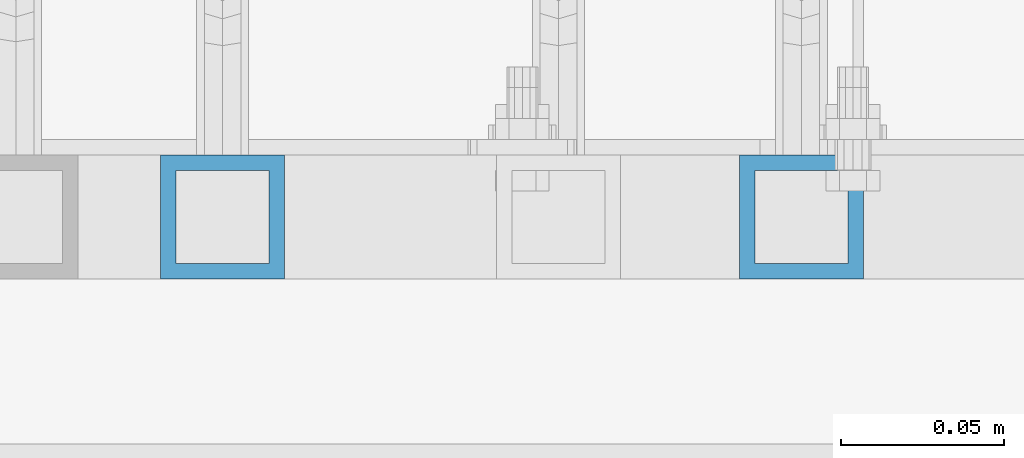
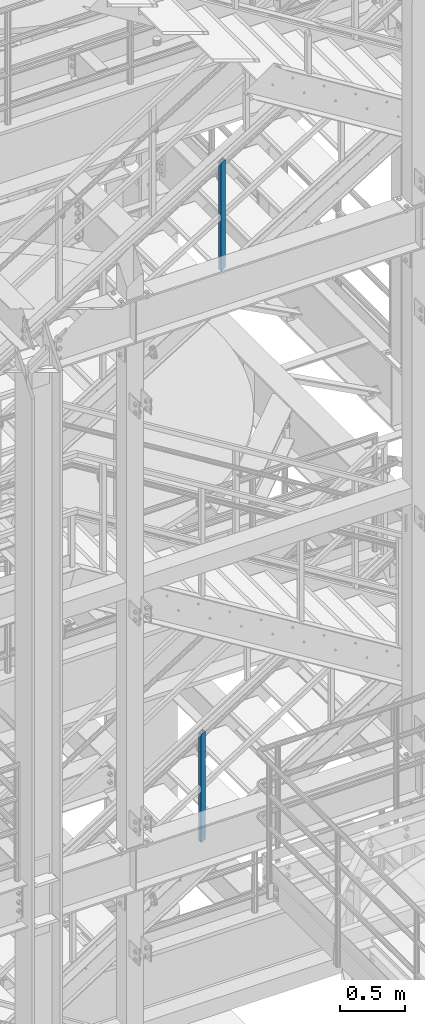
# One storey, part 624 of 1876: 2 columns, 2 elements without a shape of their own.
"""IFC2X3 building model written with IfcOpenShell, lengths in millimetres."""

from ifc_helpers import new_model, si_unit, frame, origin_with_axes, place, context, subcontext, project, spatial, faceted_brep, material, type_object, element, aggregate, save


model = new_model("IFC2X3")

# Units and contexts
model_context = context("Model", 3, precision=1e-05, world=origin_with_axes())
body_context = subcontext(model_context, "Body", "Model", "MODEL_VIEW")
ifc_project = project(units=[si_unit("LENGTHUNIT", "METRE", prefix="MILLI"), si_unit("AREAUNIT", "SQUARE_METRE"), si_unit("VOLUMEUNIT", "CUBIC_METRE"), si_unit("MASSUNIT", "GRAM", prefix="KILO"), si_unit("TIMEUNIT", "SECOND"), si_unit("PLANEANGLEUNIT", "RADIAN"), si_unit("SOLIDANGLEUNIT", "STERADIAN"), si_unit("THERMODYNAMICTEMPERATUREUNIT", "DEGREE_CELSIUS"), si_unit("LUMINOUSINTENSITYUNIT", "LUMEN")], contexts=[model_context])

# Site, building, storey
site_placement = place(None, origin_with_axes())
site = spatial("IfcSite", under=ifc_project, at=site_placement, CompositionType="ELEMENT")
building_placement = place(site_placement, origin_with_axes())
building = spatial("IfcBuilding", under=site, at=building_placement, Name="Undefined", CompositionType="ELEMENT")
storey_placement = place(building_placement, origin_with_axes())
storey = spatial("IfcBuildingStorey", under=building, at=storey_placement, Name="Undefined", CompositionType="ELEMENT", Elevation=0.0)

# Assembly, column
assembly_1_placement = place(storey_placement, origin_with_axes())
assembly_1 = element("IfcElementAssembly", 1, at=assembly_1_placement, inside=storey, Name="RAIL", AssemblyPlace="NOTDEFINED", PredefinedType="RIGID_FRAME")
ifc_material = material()
column_type = type_object("IfcColumnType", Name="HSS1-1/2X1-1/2X3/16", PredefinedType="NOTDEFINED")
column_1_placement = place(assembly_1_placement, frame((3975.09999663369, -5734.05000114554, 6843.36822224194), z_axis=(-1.0, 0.0, 0.0), x_axis=(0.0, 0.0, 1.0)))
column_1 = element("IfcColumn", 2, at=column_1_placement, type_object=column_type, material=ifc_material, Name="POST", ObjectType="HSS1-1/2X1-1/2X3/16", context=body_context, shape_type="Brep", body=[
    faceted_brep([(1026.23571825648, -19.0500000000002, -19.0499992349996), (1026.23571825648, 19.0499992349996, -19.0499992349996), (1001.99026470106, 19.0499992349996, 19.0499992349996), (1001.99026470106, -19.0499992349996, 19.0499992349996), (1023.20503656197, -14.2874994260001, -14.2874994260001), (1005.02094639574, -14.2874994260001, 14.2874994260001), (1005.02094639574, 14.2874994260001, 14.2874994260001), (1023.20503656197, 14.2874994260001, -14.2874994260001), (-12.1227267776903, 19.0499992349996, 19.0499992349996), (-12.1227267776903, -19.0499992349996, 19.0499992349996), (12.1227267777067, -19.0499992349996, -19.0499992349996), (12.1227267777067, 19.0499992349996, -19.0499992349996), (-9.09204508310631, 14.2874994260001, 14.2874994260001), (-9.09204508310631, -14.2874994260001, 14.2874994260001), (9.09204508312268, -14.2874994260001, -14.2874994260001), (9.09204508312268, 14.2874994260001, -14.2874994260001)], [[[0, 1, 2, 3], [4, 5, 6, 7]], [[8, 9, 3, 2]], [[9, 10, 0, 3]], [[10, 11, 1, 0]], [[11, 8, 2, 1]], [[10, 9, 8, 11], [12, 13, 14, 15]], [[15, 14, 4, 7]], [[12, 15, 7, 6]], [[13, 12, 6, 5]], [[14, 13, 5, 4]]]),
])
aggregate(assembly_1, [column_1])

assembly_2_placement = place(storey_placement, origin_with_axes())
assembly_2 = element("IfcElementAssembly", 3, at=assembly_2_placement, inside=storey, Name="RAIL", AssemblyPlace="NOTDEFINED", PredefinedType="RIGID_FRAME")
column_2_placement = place(assembly_2_placement, frame((4152.90000017992, -5734.05000114554, 12153.6451551716), z_axis=(-1.0, 0.0, 0.0), x_axis=(0.0, 0.0, 1.0)))
column_2 = element("IfcColumn", 4, at=column_2_placement, type_object=column_type, material=ifc_material, Name="POST", ObjectType="HSS1-1/2X1-1/2X3/16", context=body_context, shape_type="Brep", body=[
    faceted_brep([(1026.33175871902, -19.0500000000002, -19.0499992350001), (1026.33175871902, 19.0499992349996, -19.0499992350001), (1002.89450115962, 19.0499992349996, 19.0499992349996), (1002.89450115962, -19.0499992349996, 19.0499992349996), (1023.40208377724, -14.2874994260001, -14.2874994260001), (1005.82416013402, -14.2874994260001, 14.2874994260001), (1005.82416013402, 14.2874994260001, 14.2874994260001), (1023.40208377724, 14.2874994260001, -14.2874994260001), (-11.7186358969739, 19.0499992349996, 19.0499992349996), (-11.7186358969739, -19.0499992349996, 19.0499992349996), (11.7186358969793, -19.0499992349996, -19.0499992349996), (11.7186358969793, 19.0499992349996, -19.0499992349996), (-8.78902482466219, 14.2874994260001, 14.2874994260001), (-8.78902482466219, -14.2874994260001, 14.2874994260001), (8.78902482575359, -14.2874994260001, -14.2874994260001), (8.78902482575359, 14.2874994260001, -14.2874994260001)], [[[0, 1, 2, 3], [4, 5, 6, 7]], [[8, 9, 3, 2]], [[9, 10, 0, 3]], [[10, 11, 1, 0]], [[11, 8, 2, 1]], [[10, 9, 8, 11], [12, 13, 14, 15]], [[15, 14, 4, 7]], [[12, 15, 7, 6]], [[13, 12, 6, 5]], [[14, 13, 5, 4]]]),
])
aggregate(assembly_2, [column_2])

save(model, "model.ifc")
